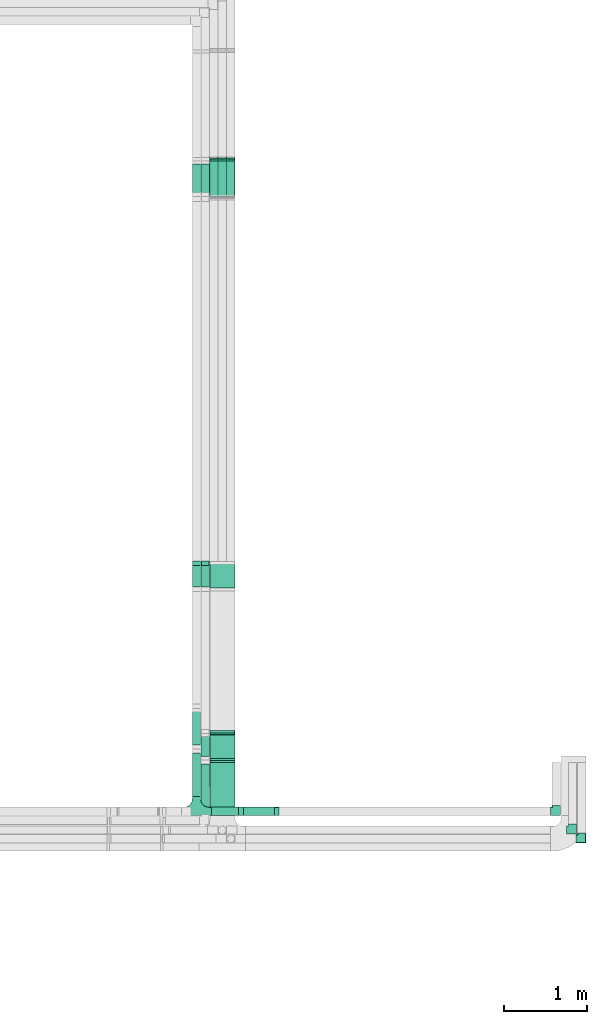
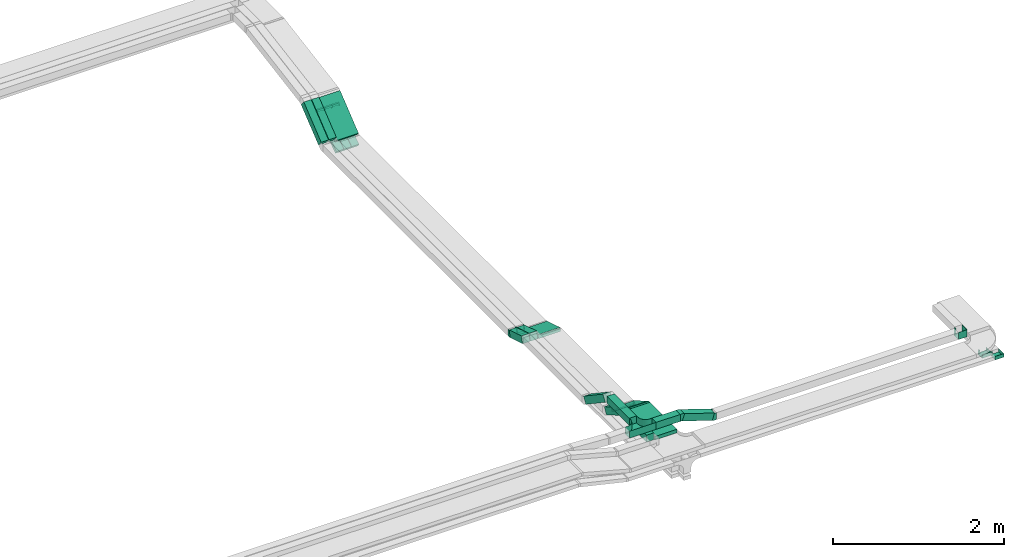
# One storey, part 14 of 18: 17 flow segments, 13 flow fittings.
"""IFC2X3 building model written with IfcOpenShell, lengths in millimetres."""

import ifcopenshell
import ifcopenshell.guid

model = None  # the IFC model being written
_history = None  # IfcOwnerHistory: only IFC2X3 demands one
_inside = {}  # id of a spatial element -> (the spatial element, [elements in it])
_under = {}  # id of a project, library or spatial element -> (it, [spatial elements below it])
_declared = {}  # id of a project -> (the project, [libraries it declares])
_typed = {}  # id of a type object -> (the type object, [elements of that type])
_made_of = {}  # id of a material, layer set ... -> (it, [elements and type objects made of it])


def new_model(schema):
    """Start an empty IFC model of exactly this schema.

    Asked for "IFC4X3", IfcOpenShell would pick the latest addendum, in which some entities
    have other attributes; the version numbers below select the first issue.
    IFC2X3 requires an IfcOwnerHistory on every rooted entity: one is made here for all.
    """
    global model, _history
    if schema == "IFC4X3":
        model = ifcopenshell.file(schema_version=(4, 3, 0, 0))
    else:
        model = ifcopenshell.file(schema=schema)
    _inside.clear()
    _under.clear()
    _declared.clear()
    _typed.clear()
    _made_of.clear()
    _history = None
    if model.schema == "IFC2X3":
        org = make("IfcOrganization", Name="unknown")
        user = make(
            "IfcPersonAndOrganization",
            ThePerson=make("IfcPerson", FamilyName="unknown"),
            TheOrganization=org,
        )
        app = make(
            "IfcApplication",
            ApplicationDeveloper=org,
            Version="unknown",
            ApplicationFullName="unknown",
            ApplicationIdentifier="unknown",
        )
        _history = make(
            "IfcOwnerHistory",
            OwningUser=user,
            OwningApplication=app,
            ChangeAction="ADDED",
            CreationDate=0,
        )
    return model


def make(cls, **values):
    """One entity of the class cls with the attributes given. An attribute that is None is left unset."""
    return model.create_entity(
        cls, **{name: value for name, value in values.items() if value is not None}
    )


def entity(cls, *values):
    """Any entity or typed value of the class cls, its attributes in the order of the schema. None: left unset."""
    e = model.create_entity(cls)
    for i, value in enumerate(values):
        if value is not None:
            e[i] = value
    return e


def rooted(cls, **values):
    """An entity with a GlobalId (a new one), such as an element, a storey or a relation."""
    return make(cls, GlobalId=ifcopenshell.guid.new(), OwnerHistory=_history, **values)


def si_unit(unit_type, name, prefix=None):
    """IfcSIUnit, for example si_unit("LENGTHUNIT", "METRE", prefix="MILLI")."""
    return make("IfcSIUnit", UnitType=unit_type, Prefix=prefix, Name=name)


def converted_unit(unit_type, name, factor, base, dimensions=None, offset=None):
    """IfcConversionBasedUnit, such as the inch: factor (a typed value) times the base unit."""
    return make(
        "IfcConversionBasedUnit"
        if offset is None
        else "IfcConversionBasedUnitWithOffset",
        ConversionOffset=offset,
        Dimensions=None
        if dimensions is None
        else entity("IfcDimensionalExponents", *dimensions),
        UnitType=unit_type,
        Name=name,
        ConversionFactor=make(
            "IfcMeasureWithUnit", ValueComponent=factor, UnitComponent=base
        ),
    )


def derived_unit(unit_type, elements):
    """IfcDerivedUnit: a product of units, each with its exponent."""
    return make(
        "IfcDerivedUnit",
        Elements=[
            make("IfcDerivedUnitElement", Unit=unit, Exponent=power)
            for unit, power in elements
        ],
        UnitType=unit_type,
    )


def assignment(units):
    """IfcUnitAssignment: the units of a project."""
    return None if units is None else make("IfcUnitAssignment", Units=units)


def point(xyz):
    """IfcCartesianPoint."""
    return None if xyz is None else make("IfcCartesianPoint", Coordinates=xyz)


def direction(xyz):
    """IfcDirection."""
    return None if xyz is None else make("IfcDirection", DirectionRatios=xyz)


def frame(location, z_axis=None, x_axis=None):
    """IfcAxis2Placement3D, a coordinate frame: its origin and axes. An axis left out is left unset."""
    return make(
        "IfcAxis2Placement3D",
        Location=point(location),
        Axis=direction(z_axis),
        RefDirection=direction(x_axis),
    )


def frame_2d(location, x_axis=None):
    """IfcAxis2Placement2D, a coordinate frame in the plane: its origin and x axis."""
    return make(
        "IfcAxis2Placement2D", Location=point(location), RefDirection=direction(x_axis)
    )


def origin():
    """The frame at (0, 0, 0) with its axes left unset."""
    return frame((0.0, 0.0, 0.0))


def origin_2d_with_axis():
    """The frame at (0, 0) in the plane with the x axis (1, 0) written out."""
    return frame_2d((0.0, 0.0), x_axis=(1.0, 0.0))


def place(relative_to, where):
    """IfcLocalPlacement: puts the frame where relative to a parent placement (None: the world)."""
    return make(
        "IfcLocalPlacement", PlacementRelTo=relative_to, RelativePlacement=where
    )


def context(
    kind, dimensions, precision=None, world=None, true_north=None, identifier=None
):
    """IfcGeometricRepresentationContext, for example the 3D "Model" context."""
    return make(
        "IfcGeometricRepresentationContext",
        ContextIdentifier=identifier,
        ContextType=kind,
        CoordinateSpaceDimension=dimensions,
        Precision=precision,
        WorldCoordinateSystem=world,
        TrueNorth=true_north,
    )


def subcontext(parent, identifier, kind, view, scale=None):
    """IfcGeometricRepresentationSubContext, for example "Body" below "Model"."""
    return make(
        "IfcGeometricRepresentationSubContext",
        ContextIdentifier=identifier,
        ContextType=kind,
        ParentContext=parent,
        TargetScale=scale,
        TargetView=view,
    )


def project(units=None, contexts=None):
    """IfcProject with its units and contexts."""
    return rooted(
        "IfcProject",
        Name="project",
        RepresentationContexts=contexts,
        UnitsInContext=assignment(units),
    )


def spatial(cls, under=None, at=None, **own):
    """A site, building, storey or space (cls), placed at a placement, below another one or the project."""
    s = rooted(cls, ObjectPlacement=at, **own)
    if under is not None:
        _under.setdefault(under.id(), (under, []))[1].append(s)
    return s


def profile(cls, at=None, kind="AREA", **sizes):
    """A parametric profile (cls). Its sizes go by their IFC names, for example OverallWidth=200.0."""
    return make(cls, ProfileType=kind, Position=at, **sizes)


def rectangle(**sizes):
    """IfcRectangleProfileDef."""
    return profile("IfcRectangleProfileDef", **sizes)


def extrude(swept, where, along, depth):
    """IfcExtrudedAreaSolid: the profile swept, set in the frame where, extruded along a direction by depth."""
    return make(
        "IfcExtrudedAreaSolid",
        SweptArea=swept,
        Position=where,
        ExtrudedDirection=direction(along),
        Depth=depth,
    )


def faces_of(points, faces, orient=None, outer=None):
    """IfcFace entities. A face is a list of loops; a loop is a list of indices into points, from 0.

    orient and outer hold one flag for each loop. By default every Orientation is true, the
    first loop of a face is its IfcFaceOuterBound and the others are IfcFaceBound.
    """
    made = []
    for i, loops in enumerate(faces):
        bounds = []
        for j, loop in enumerate(loops):
            is_outer = j == 0 if outer is None else outer[i][j]
            bounds.append(
                make(
                    "IfcFaceOuterBound" if is_outer else "IfcFaceBound",
                    Bound=make("IfcPolyLoop", Polygon=[points[k] for k in loop]),
                    Orientation=True if orient is None else orient[i][j],
                )
            )
        made.append(make("IfcFace", Bounds=bounds))
    return made


def faceted_brep(points, faces, orient=None, outer=None, voids=None):
    """IfcFacetedBrep: a solid bounded by flat faces; with voids (closed shells), ...WithVoids."""
    shared = [point(p) for p in points]
    hull = make("IfcClosedShell", CfsFaces=faces_of(shared, faces, orient, outer))
    if voids is None:
        return make("IfcFacetedBrep", Outer=hull)
    return make(
        "IfcFacetedBrepWithVoids",
        Outer=hull,
        Voids=[
            make(cls, CfsFaces=faces_of(shared, fs, o, b)) for cls, fs, o, b in voids
        ],
    )


def shape(context_of_items, identifier, shape_type, items):
    """IfcShapeRepresentation: the items that make up one representation, for example the "Body"."""
    return make(
        "IfcShapeRepresentation",
        ContextOfItems=context_of_items,
        RepresentationIdentifier=identifier,
        RepresentationType=shape_type,
        Items=items,
    )


def source(mapping_origin, context_of_items, identifier, shape_type, items):
    """IfcRepresentationMap: a shape defined once, which mapped items show again and again."""
    return make(
        "IfcRepresentationMap",
        MappingOrigin=mapping_origin,
        MappedRepresentation=shape(context_of_items, identifier, shape_type, items),
    )


def transform(
    local_origin,
    x_axis=None,
    y_axis=None,
    z_axis=None,
    scale=None,
    scale2=None,
    scale3=None,
    uniform=True,
):
    """IfcCartesianTransformationOperator3D, or its non-uniform kind. x_axis, y_axis, z_axis: its Axis1, 2, 3."""
    if uniform:
        return make(
            "IfcCartesianTransformationOperator3D",
            Axis1=direction(x_axis),
            Axis2=direction(y_axis),
            LocalOrigin=point(local_origin),
            Scale=scale,
            Axis3=direction(z_axis),
        )
    return make(
        "IfcCartesianTransformationOperator3DnonUniform",
        Axis1=direction(x_axis),
        Axis2=direction(y_axis),
        LocalOrigin=point(local_origin),
        Scale=scale,
        Axis3=direction(z_axis),
        Scale2=scale2,
        Scale3=scale3,
    )


def mapped(mapping_source, mapping_target):
    """IfcMappedItem: shows the shape of a source again, moved by a transform."""
    return make(
        "IfcMappedItem", MappingSource=mapping_source, MappingTarget=mapping_target
    )


def material(Name=None, Category=None):
    """IfcMaterial."""
    return make("IfcMaterial", Name=Name, Category=Category)


def made_of(thing, what):
    """Note that an element or type object is made of a material, layer set ...; save() writes the relation."""
    if what is not None:
        _made_of.setdefault(what.id(), (what, []))[1].append(thing)
    return thing


def type_object(cls, material=None, **own):
    """A type object (cls), such as IfcWallType, which elements share."""
    return made_of(rooted(cls, **own), material)


def type_shapes(of_type, sources):
    """Give a type object the sources (RepresentationMaps) that its elements show as mapped items."""
    of_type.RepresentationMaps = sources


def element(
    cls,
    number,
    at=None,
    inside=None,
    cuts=None,
    type_object=None,
    material=None,
    context=None,
    identifier="Body",
    shape_type=None,
    held_by="IfcProductDefinitionShape",
    body=None,
    shapes=None,
    **own,
):
    """One element of the class cls, such as IfcWall. Its Tag is "e" and its number.

    at: its placement. inside: the storey or other place that contains it. cuts: it is an
    opening in that element (IfcRelVoidsElement). A single representation is given by context,
    identifier, shape_type and body (its items); several are given by shapes. held_by: the class
    of the entity that holds the representations. save() writes the other relations.
    """
    e = rooted(cls, Tag="e%d" % number, ObjectPlacement=at, **own)
    if body is not None:
        shapes = [shape(context, identifier, shape_type, body)]
    if shapes is not None:
        e.Representation = make(held_by, Representations=shapes)
    if inside is not None:
        _inside.setdefault(inside.id(), (inside, []))[1].append(e)
    if cuts is not None:
        rooted(
            "IfcRelVoidsElement", RelatingBuildingElement=cuts, RelatedOpeningElement=e
        )
    if type_object is not None:
        _typed.setdefault(type_object.id(), (type_object, []))[1].append(e)
    return made_of(e, material)


def aggregate(whole, parts):
    """IfcRelAggregates: a whole, such as a stair, and the parts it consists of."""
    return rooted("IfcRelAggregates", RelatingObject=whole, RelatedObjects=parts)


def save(model, path):
    """Write the relations noted so far, then the file.

    IfcRelAggregates (storeys below a building ...), IfcRelContainedInSpatialStructure (elements
    in a storey), IfcRelDefinesByType, IfcRelAssociatesMaterial and IfcRelDeclares: one each for
    every whole, place, type object, material and project.
    """
    for whole, parts in _under.values():
        aggregate(whole, parts)
    for where, things in _inside.values():
        rooted(
            "IfcRelContainedInSpatialStructure",
            RelatedElements=things,
            RelatingStructure=where,
        )
    for kind, things in _typed.values():
        rooted("IfcRelDefinesByType", RelatedObjects=things, RelatingType=kind)
    for what, things in _made_of.values():
        rooted("IfcRelAssociatesMaterial", RelatedObjects=things, RelatingMaterial=what)
    for by, libraries in _declared.values():
        rooted("IfcRelDeclares", RelatingContext=by, RelatedDefinitions=libraries)
    model.write(path)


model = new_model("IFC2X3")

# Units and contexts
model_context = context("Model", 3, precision=0.01, world=origin(), true_north=direction((6.12303176911189e-17, 1.0)))
body_context = subcontext(model_context, "Body", "Model", "MODEL_VIEW")
ifc_project = project(units=[si_unit("LENGTHUNIT", "METRE", prefix="MILLI"), si_unit("AREAUNIT", "SQUARE_METRE"), si_unit("VOLUMEUNIT", "CUBIC_METRE"), converted_unit("PLANEANGLEUNIT", "DEGREE", entity("IfcRatioMeasure", 0.0174532925199433), si_unit("PLANEANGLEUNIT", "RADIAN"), dimensions=[0, 0, 0, 0, 0, 0, 0]), si_unit("MASSUNIT", "GRAM", prefix="KILO"), derived_unit("MASSDENSITYUNIT", [(si_unit("MASSUNIT", "GRAM", prefix="KILO"), 1), (si_unit("LENGTHUNIT", "METRE"), -3)]), derived_unit("MOMENTOFINERTIAUNIT", [(si_unit("LENGTHUNIT", "METRE"), 4)]), si_unit("TIMEUNIT", "SECOND"), si_unit("FREQUENCYUNIT", "HERTZ"), si_unit("THERMODYNAMICTEMPERATUREUNIT", "DEGREE_CELSIUS"), derived_unit("THERMALTRANSMITTANCEUNIT", [(si_unit("MASSUNIT", "GRAM", prefix="KILO"), 1), (si_unit("THERMODYNAMICTEMPERATUREUNIT", "KELVIN"), -1), (si_unit("TIMEUNIT", "SECOND"), -3)]), derived_unit("VOLUMETRICFLOWRATEUNIT", [(si_unit("LENGTHUNIT", "METRE"), 3), (si_unit("TIMEUNIT", "SECOND"), -1)]), derived_unit("MASSFLOWRATEUNIT", [(si_unit("MASSUNIT", "GRAM", prefix="KILO"), 1), (si_unit("TIMEUNIT", "SECOND"), -1)]), derived_unit("ROTATIONALFREQUENCYUNIT", [(si_unit("TIMEUNIT", "SECOND"), -1)]), si_unit("ELECTRICCURRENTUNIT", "AMPERE"), si_unit("ELECTRICVOLTAGEUNIT", "VOLT"), si_unit("POWERUNIT", "WATT"), si_unit("FORCEUNIT", "NEWTON", prefix="KILO"), si_unit("ILLUMINANCEUNIT", "LUX"), si_unit("LUMINOUSFLUXUNIT", "LUMEN"), si_unit("LUMINOUSINTENSITYUNIT", "CANDELA"), derived_unit("USERDEFINED", [(si_unit("MASSUNIT", "GRAM", prefix="KILO"), -1), (si_unit("LENGTHUNIT", "METRE"), -2), (si_unit("TIMEUNIT", "SECOND"), 3), (si_unit("LUMINOUSFLUXUNIT", "LUMEN"), 1)]), derived_unit("LINEARVELOCITYUNIT", [(si_unit("LENGTHUNIT", "METRE"), 1), (si_unit("TIMEUNIT", "SECOND"), -1)]), si_unit("PRESSUREUNIT", "PASCAL"), derived_unit("USERDEFINED", [(si_unit("LENGTHUNIT", "METRE"), -2), (si_unit("MASSUNIT", "GRAM", prefix="KILO"), 1), (si_unit("TIMEUNIT", "SECOND"), -2)]), derived_unit("LINEARFORCEUNIT", [(si_unit("MASSUNIT", "GRAM", prefix="KILO"), 1), (si_unit("LENGTHUNIT", "METRE"), 1), (si_unit("TIMEUNIT", "SECOND"), -2), (si_unit("LENGTHUNIT", "METRE"), -1)]), derived_unit("PLANARFORCEUNIT", [(si_unit("MASSUNIT", "GRAM", prefix="KILO"), 1), (si_unit("LENGTHUNIT", "METRE"), 1), (si_unit("TIMEUNIT", "SECOND"), -2), (si_unit("LENGTHUNIT", "METRE"), -2)])], contexts=[model_context])

# Site, building, storey
site_placement = place(None, frame((0.0, -0.00077364408347762, 0.0)))
site = spatial("IfcSite", under=ifc_project, at=site_placement, CompositionType="ELEMENT")
building_placement = place(site_placement, origin())
building = spatial("IfcBuilding", under=site, at=building_placement, CompositionType="ELEMENT")
storey_placement = place(building_placement, frame((0.0, 0.0, 19800.0)))
storey = spatial("IfcBuildingStorey", under=building, at=storey_placement, CompositionType="ELEMENT", Elevation=19800.0)

# Flow segments
cable_carrier_segment_type = type_object("IfcCableCarrierSegmentType", PredefinedType="CABLETRAYSEGMENT")
flow_segment_1_placement = place(storey_placement, frame((64391.9138834223, 17411.1480452111, 2720.97492503869)))
element("IfcFlowSegment", 1, at=flow_segment_1_placement, inside=storey, type_object=cable_carrier_segment_type, context=body_context, shape_type="SweptSolid", body=[
    extrude(rectangle(XDim=49.9999999999999, YDim=558.364474472639, at=frame_2d((5.11590769747272e-13, 2.36788366692053e-12), x_axis=(0.0, 1.0))), frame((0.0, 232.698357954974, 195.123723748153), z_axis=(1.0, 0.0, 0.0), x_axis=(0.0, -0.777145961456977, -0.62932039104983)), (0.0, 0.0, 1.0), 300.000000000001),
])
flow_segment_2_placement = place(storey_placement, frame((64285.5285540871, 17401.0506289851, 2737.8789554889)))
element("IfcFlowSegment", 2, at=flow_segment_2_placement, inside=storey, type_object=cable_carrier_segment_type, context=body_context, shape_type="SweptSolid", body=[
    extrude(rectangle(XDim=100.000000000002, YDim=99.9999999999916, at=origin_2d_with_axis()), frame((50.0167972546053, 31.4672641902552, 38.8583059544737), z_axis=(-3.20308930122839e-05, 0.777145960996682, 0.6293203908031), x_axis=(0.0, -0.629320391125934, 0.777145961395349)), (0.0, 0.0, 1.0), 524.408740760887),
])
flow_segment_3_placement = place(storey_placement, frame((64180.0593442443, 17401.0504555113, 2737.87881503436)))
element("IfcFlowSegment", 3, at=flow_segment_3_placement, inside=storey, type_object=cable_carrier_segment_type, context=body_context, shape_type="SweptSolid", body=[
    extrude(rectangle(XDim=100.000000000001, YDim=99.9999999999946, at=frame_2d((6.78568312650896e-13, 0.0), x_axis=(1.0, 0.0))), frame((50.0, 31.4660195524966, 38.8572980728524), z_axis=(0.0, 0.777145961456953, 0.62932039104986), x_axis=(0.0, -0.62932039104986, 0.777145961456953)), (0.0, 0.0, 1.0), 524.410565226229),
])
flow_segment_4_placement = place(storey_placement, frame((64593.0376989449, 17401.2001656463, 2566.87354238661)))
element("IfcFlowSegment", 4, at=flow_segment_4_placement, inside=storey, type_object=cable_carrier_segment_type, context=body_context, shape_type="SweptSolid", body=[
    extrude(rectangle(XDim=50.0000000000052, YDim=534.379820039847, at=frame_2d((0.0, 0.0), x_axis=(0.0, 1.0))), frame((0.0, 234.433439273437, 171.822768986589), z_axis=(1.0, 0.0, 0.0), x_axis=(0.0, 0.824451507844614, 0.565932603065721)), (0.0, 0.0, 1.0), 99.9999999999946),
])
for number, where in (
    (5, (64490.5275144406, 17401.2001656506, 2566.87354238954)),
    (6, (64388.5726926723, 17401.2001656506, 2566.87354238954)),
):
    element("IfcFlowSegment", number, at=place(storey_placement, frame(where)), inside=storey, type_object=cable_carrier_segment_type, context=body_context, shape_type="SweptSolid", body=[
        extrude(rectangle(XDim=50.0000000000052, YDim=534.379820034669, at=frame_2d((0.0, 0.0), x_axis=(0.0, 1.0))), frame((0.0, 234.433439271302, 171.822768985125), z_axis=(1.0, 0.0, 0.0), x_axis=(0.0, 0.824451507844611, 0.565932603065725)), (0.0, 0.0, 1.0), 99.9999999999946),
    ])
flow_segment_5_placement = place(storey_placement, frame((64393.0376989449, 9945.00008284603, 3000.0)))
element("IfcFlowSegment", 7, at=flow_segment_5_placement, inside=storey, type_object=cable_carrier_segment_type, context=body_context, shape_type="SweptSolid", body=[
    extrude(rectangle(XDim=637.211482764682, YDim=300.000000000001, at=frame_2d((1.10844666778576e-12, -4.33431068813661e-12), x_axis=(1.0, 0.0))), frame((150.0, 318.60574138234, 0.0), z_axis=(0.0, 0.0, 1.0), x_axis=(0.0, 1.0, 0.0)), (0.0, 0.0, 1.0), 49.9999999999973),
])
flow_segment_6_placement = place(storey_placement, frame((64393.0376989449, 10606.5416926296, 2813.21796769732)))
element("IfcFlowSegment", 8, at=flow_segment_6_placement, inside=storey, type_object=cable_carrier_segment_type, context=body_context, shape_type="SweptSolid", body=[
    extrude(rectangle(XDim=49.9999999999989, YDim=360.525588832415, at=frame_2d((-2.95585778076202e-12, 7.95807864051312e-13), x_axis=(0.0, 1.0))), frame((0.0, 168.612159321606, 111.782032302714), z_axis=(1.0, 0.0, 0.0), x_axis=(0.0, 0.866025403784418, -0.500000000000036)), (0.0, 0.0, 1.0), 300.000000000001),
])
flow_segment_7_placement = place(storey_placement, frame((64285.5467024828, 10605.6442330113, 2823.26916208132)))
element("IfcFlowSegment", 9, at=flow_segment_7_placement, inside=storey, type_object=cable_carrier_segment_type, context=body_context, shape_type="SweptSolid", body=[
    extrude(rectangle(XDim=99.9999999999989, YDim=99.9999999999946, at=origin_2d_with_axis()), frame((50.0, 25.0, 210.16350531605), z_axis=(0.0, 0.866025403784326, -0.500000000000195), x_axis=(0.0, 0.500000000000195, 0.866025403784326)), (0.0, 0.0, 1.0), 333.724470253517),
])
flow_segment_8_placement = place(storey_placement, frame((64285.5467024828, 9956.0000815939, 3000.0)))
element("IfcFlowSegment", 10, at=flow_segment_8_placement, inside=storey, type_object=cable_carrier_segment_type, context=body_context, shape_type="SweptSolid", body=[
    extrude(rectangle(XDim=612.814024398429, YDim=99.9999999999946, at=frame_2d((0.0, 4.33075797445781e-12), x_axis=(1.0, 0.0))), frame((50.0, 306.407012199218, 0.0), z_axis=(0.0, 0.0, 1.0), x_axis=(0.0, 1.0, 0.0)), (0.0, 0.0, 1.0), 100.000000000003),
])
flow_segment_9_placement = place(storey_placement, frame((64180.0597687348, 10175.000082846, 3146.68251695043)))
element("IfcFlowSegment", 11, at=flow_segment_9_placement, inside=storey, type_object=cable_carrier_segment_type, context=body_context, shape_type="SweptSolid", body=[
    extrude(rectangle(XDim=523.063851606019, YDim=99.9999999999946, at=origin_2d_with_axis()), frame((50.0, 261.53192580301, 0.0), z_axis=(0.0, 0.0, 1.0), x_axis=(0.0, 1.0, 0.0)), (0.0, 0.0, 1.0), 100.000000000003),
])
flow_segment_10_placement = place(storey_placement, frame((64765.1718243244, 9945.00008284604, 3009.28144340263)))
element("IfcFlowSegment", 12, at=flow_segment_10_placement, inside=storey, type_object=cable_carrier_segment_type, context=body_context, shape_type="SweptSolid", body=[
    extrude(rectangle(XDim=99.9999999999972, YDim=99.9999999999989, at=origin_2d_with_axis()), frame((15.5858337745195, 50.0, 180.610875314588), z_axis=(0.950175096611784, 0.0, -0.311716675490399), x_axis=(0.311716675490399, 0.0, 0.950175096611784)), (0.0, 0.0, 1.0), 426.997112921798),
])
flow_segment_11_placement = place(storey_placement, frame((64410.0597687348, 9945.00008284604, 3146.68251695043)))
element("IfcFlowSegment", 13, at=flow_segment_11_placement, inside=storey, type_object=cable_carrier_segment_type, context=body_context, shape_type="SweptSolid", body=[
    extrude(rectangle(XDim=328.216762954596, YDim=99.9999999999989, at=origin_2d_with_axis()), frame((164.108381477298, 50.0, 0.0)), (0.0, 0.0, 1.0), 100.000000000003),
])
flow_segment_12_placement = place(storey_placement, frame((64180.0597687348, 10737.8410861841, 2829.0378787811)))
element("IfcFlowSegment", 14, at=flow_segment_12_placement, inside=storey, type_object=cable_carrier_segment_type, context=body_context, shape_type="SweptSolid", body=[
    extrude(rectangle(XDim=99.9999999999974, YDim=99.9999999999946, at=frame_2d((0.0, 8.66506866259442e-12), x_axis=(1.0, 0.0))), frame((50.0, 27.8399213668352, 347.078648831679), z_axis=(0.0, 0.830647645705059, -0.556798427336718), x_axis=(0.0, 0.556798427336718, 0.830647645705059)), (0.0, 0.0, 1.0), 548.755620607478),
])
flow_segment_13_placement = place(storey_placement, frame((64393.0376989449, 12673.6918025553, 2704.95747891862)))
element("IfcFlowSegment", 15, at=flow_segment_13_placement, inside=storey, type_object=cable_carrier_segment_type, context=body_context, shape_type="SweptSolid", body=[
    extrude(rectangle(XDim=50.0000000000024, YDim=315.590748852371, at=frame_2d((0.0, 0.0), x_axis=(0.0, 1.0))), frame((0.0, 158.209759650795, 70.0425215174395), z_axis=(1.0, 0.0, 0.0), x_axis=(0.0, 0.956304755963003, -0.292371704722843)), (0.0, 0.0, 1.0), 300.000000000001),
])
flow_segment_14_placement = place(storey_placement, frame((64285.5467024828, 12676.6495457763, 2708.42445845428)))
element("IfcFlowSegment", 16, at=flow_segment_14_placement, inside=storey, type_object=cable_carrier_segment_type, context=body_context, shape_type="SweptSolid", body=[
    extrude(rectangle(XDim=100.000000000005, YDim=99.9999999999946, at=frame_2d((0.0, 3.19744231092045e-13), x_axis=(0.0, 1.0))), frame((50.0, 14.6185852361423, 135.713790648688), z_axis=(0.0, 0.956304755963, -0.292371704722853), x_axis=(-1.0, 0.0, 0.0)), (0.0, 0.0, 1.0), 300.639738492675),
])
flow_segment_15_placement = place(storey_placement, frame((64180.0597687348, 12676.6507563411, 2708.42445845429)))
element("IfcFlowSegment", 17, at=flow_segment_15_placement, inside=storey, type_object=cable_carrier_segment_type, context=body_context, shape_type="SweptSolid", body=[
    extrude(rectangle(XDim=100.000000000005, YDim=99.9999999999946, at=frame_2d((-8.66506866259442e-12, 0.0), x_axis=(0.0, 1.0))), frame((50.0, 14.6185852361423, 135.713420541873), z_axis=(0.0, 0.956304755963006, -0.292371704722833), x_axis=(-1.0, 0.0, 0.0)), (0.0, 0.0, 1.0), 300.63847261503),
])

# Flow fittings
ifc_material = material()
cable_carrier_fitting_type_1 = type_object("IfcCableCarrierFittingType", PredefinedType="NOTDEFINED", material=ifc_material)
shared_shape_1 = source(origin(), body_context, "Body", "Brep", [
    faceted_brep([(-17.0803377956261, -25.0, 50.0), (-17.080337795626, 25.0, 50.0), (-17.080337795626, 25.0, 47.4600000101635), (-17.0803377956261, -22.4600000101599, 47.4600000101635), (-17.0803377956261, -22.4600000101599, -47.4600000101565), (-17.080337795626, 25.0, -47.4600000101565), (-17.080337795626, 25.0, -50.0), (-17.0803377956261, -25.0, -50.0), (25.9848753027497, -15.5410487005638, 50.0), (25.9848753027497, -15.5410487005638, -50.0), (5.03147604697358, 29.8566941907743, -50.0), (5.03147604697358, 29.8566941907743, -47.4600000101565), (24.920442624814, -13.2348433709087, -47.4600000101565), (24.920442624814, -13.2348433709087, 47.4600000101635), (5.03147604697358, 29.8566941907743, 47.4600000101635), (5.03147604697358, 29.8566941907743, 50.0), (5.49106263437606, -25.0, 50.0), (-5.49106263437527, 25.0, 50.0), (-5.49106263437527, 25.0, 47.4600000101635), (4.93317067295496, -22.46000001016, 47.4600000101635), (4.93317067295496, -22.46000001016, -47.4600000101565), (-5.49106263437527, 25.0, -47.4600000101565), (-5.49106263437526, 25.0, -50.0), (5.49106263437596, -25.0, -50.0)], [[[0, 1, 2, 3, 4, 5, 6, 7]], [[8, 9, 10, 11, 12, 13, 14, 15]], [[1, 0, 16, 8, 15, 17]], [[2, 1, 17, 18]], [[3, 2, 18, 14, 13, 19]], [[4, 3, 19, 20]], [[5, 4, 20, 12, 11, 21]], [[6, 5, 21, 22]], [[7, 6, 22, 10, 9, 23]], [[0, 7, 23, 16]], [[18, 17, 15, 14]], [[20, 19, 13, 12]], [[22, 21, 11, 10]], [[16, 23, 9, 8]]]),
])
type_shapes(cable_carrier_fitting_type_1, [shared_shape_1])
for number, where, z_axis, x_axis in (
    (18, (64643.0376989449, 17870.0006393666, 2899.57411269359), (1.0, 0.0, 0.0), (0.0, -0.985728987268033, -0.168340023938269)),
    (19, (64540.5275144406, 17870.0006393666, 2899.5741126936), (1.0, 0.0, 0.0), (0.0, -0.985728987268033, -0.168340023938269)),
    (20, (64438.5726926723, 17870.0006393666, 2899.5741126936), (1.0, 0.0, 0.0), (0.0, -0.985728987268033, -0.168340023938269)),
):
    element("IfcFlowFitting", number, at=place(storey_placement, frame(where, z_axis=z_axis, x_axis=x_axis)), inside=storey, type_object=cable_carrier_fitting_type_1, material=ifc_material, context=body_context, shape_type="MappedRepresentation", body=[
        mapped(shared_shape_1, transform((0.0, 0.0, 0.0), scale=1.0)),
    ])
cable_carrier_fitting_type_2 = type_object("IfcCableCarrierFittingType", PredefinedType="NOTDEFINED", material=ifc_material)
shared_shape_2 = source(origin(), body_context, "Body", "Brep", [
    faceted_brep([(-70.0, 50.0, -25.0), (-70.0, -50.0, -25.0), (-70.0, -50.0, 25.0), (-70.0, -47.4600000101598, 25.0), (-70.0, -47.4600000101598, -22.4600000101565), (-70.0, 47.4600000101602, -22.4600000101565), (-70.0, 47.4600000101602, 25.0), (-70.0, 50.0, 25.0), (-50.0, 50.0, -25.0), (-50.0, 70.0, -25.0), (50.0, 70.0, -25.0), (50.0, -50.0, -25.0), (50.0, -50.0, 25.0), (50.0, 70.0, 25.0), (47.4600000101603, 70.0, 25.0), (47.4600000101596, -47.4600000101602, 25.0), (47.4600000101596, -47.4600000101602, -22.4600000101565), (47.4600000101603, 70.0, -22.4600000101565), (-47.4600000101597, 70.0, -22.4600000101565), (-47.4600000101602, 47.4600000101602, -22.4600000101565), (-47.4600000101602, 47.4600000101602, 25.0), (-47.4600000101597, 70.0, 25.0), (-50.0, 70.0, 25.0), (-50.0, 50.0, 25.0)], [[[0, 1, 2, 3, 4, 5, 6, 7]], [[1, 0, 8, 9, 10, 11]], [[2, 1, 11, 12]], [[3, 2, 12, 13, 14, 15]], [[4, 3, 15, 16]], [[5, 4, 16, 17, 18, 19]], [[6, 5, 19, 20]], [[7, 6, 20, 21, 22, 23]], [[0, 7, 23, 8]], [[9, 22, 21, 18, 17, 14, 13, 10]], [[12, 11, 10, 13]], [[16, 15, 14, 17]], [[20, 19, 18, 21]], [[8, 23, 22, 9]]]),
])
type_shapes(cable_carrier_fitting_type_2, [shared_shape_2])
for number, where in (
    (21, (68767.4381955181, 9770.00008284602, 2825.0)),
    (22, (68880.581617303, 9665.00008284603, 2825.0)),
):
    element("IfcFlowFitting", number, at=place(storey_placement, frame(where)), inside=storey, type_object=cable_carrier_fitting_type_2, material=ifc_material, context=body_context, shape_type="MappedRepresentation", body=[
        mapped(shared_shape_2, transform((0.0, 0.0, 0.0), scale=1.0)),
    ])
cable_carrier_fitting_type_3 = type_object("IfcCableCarrierFittingType", PredefinedType="NOTDEFINED", material=ifc_material)
shared_shape_3 = source(origin(), body_context, "Body", "Brep", [
    faceted_brep([(-19.7372055837126, -25.0, 150.0), (-19.7372055837125, 25.0, 150.0), (-19.7372055837125, 25.0, 147.460000010164), (-19.7372055837126, -22.4600000101599, 147.460000010164), (-19.7372055837126, -22.4600000101599, -147.460000010156), (-19.7372055837125, 25.0, -147.460000010156), (-19.7372055837125, 25.0, -150.0), (-19.7372055837126, -25.0, -150.0), (29.5929214352125, -11.7820323027537, 150.0), (29.5929214352125, -11.7820323027538, -150.0), (4.59292143521078, 31.5192378864672, -150.0), (4.59292143521077, 31.5192378864672, -147.460000010156), (28.3229214402924, -9.58232778594015, -147.460000010156), (28.3229214402924, -9.58232778594014, 147.460000010164), (4.59292143521078, 31.5192378864672, 147.460000010164), (4.59292143521077, 31.5192378864672, 150.0), (6.69872981077903, -25.0, 150.0), (-6.69872981077822, 25.0, 150.0), (-6.69872981077822, 25.0, 147.460000010164), (6.01813886472617, -22.46000001016, 147.460000010164), (6.01813886472617, -22.46000001016, -147.460000010156), (-6.69872981077822, 25.0, -147.460000010156), (-6.69872981077822, 25.0, -150.0), (6.69872981077891, -25.0, -150.0)], [[[0, 1, 2, 3, 4, 5, 6, 7]], [[8, 9, 10, 11, 12, 13, 14, 15]], [[1, 0, 16, 8, 15, 17]], [[2, 1, 17, 18]], [[3, 2, 18, 14, 13, 19]], [[4, 3, 19, 20]], [[5, 4, 20, 12, 11, 21]], [[6, 5, 21, 22]], [[7, 6, 22, 10, 9, 23]], [[0, 7, 23, 16]], [[18, 17, 15, 14]], [[20, 19, 13, 12]], [[22, 21, 11, 10]], [[16, 23, 9, 8]]]),
])
type_shapes(cable_carrier_fitting_type_3, [shared_shape_3])
for number, where, z_axis, x_axis in (
    (23, (64543.0376989449, 10601.9487711944, 3025.0), (-1.0, 0.0, 0.0), (0.0, 1.0, 0.0)),
    (24, (64543.0376989449, 10948.3589327081, 2825.0), (1.0, 0.0, 0.0), (0.0, 0.866025403784418, -0.500000000000036)),
):
    element("IfcFlowFitting", number, at=place(storey_placement, frame(where, z_axis=z_axis, x_axis=x_axis)), inside=storey, type_object=cable_carrier_fitting_type_3, material=ifc_material, context=body_context, shape_type="MappedRepresentation", body=[
        mapped(shared_shape_3, transform((0.0, 0.0, 0.0), scale=1.0)),
    ])
cable_carrier_fitting_type_4 = type_object("IfcCableCarrierFittingType", PredefinedType="NOTDEFINED", material=ifc_material)
shared_shape_4 = source(origin(), body_context, "Body", "Brep", [
    faceted_brep([(-70.0, 50.0, -50.0), (-70.0, -50.0, -50.0), (-70.0, -50.0, 50.0), (-70.0, -47.4600000101598, 50.0), (-70.0, -47.4600000101598, -47.4600000101565), (-70.0, 47.4600000101602, -47.4600000101565), (-70.0, 47.4600000101602, 50.0), (-70.0, 50.0, 50.0), (-50.0, 50.0, -50.0), (-50.0, 70.0, -50.0), (50.0, 70.0, -50.0), (50.0, -50.0, -50.0), (50.0, -50.0, 50.0), (50.0, 70.0, 50.0), (47.4600000101603, 70.0, 50.0), (47.4600000101596, -47.4600000101602, 50.0), (47.4600000101596, -47.4600000101602, -47.4600000101565), (47.4600000101603, 70.0, -47.4600000101565), (-47.4600000101597, 70.0, -47.4600000101565), (-47.4600000101602, 47.4600000101602, -47.4600000101565), (-47.4600000101602, 47.4600000101602, 50.0), (-47.4600000101597, 70.0, 50.0), (-50.0, 70.0, 50.0), (-50.0, 50.0, 50.0)], [[[0, 1, 2, 3, 4, 5, 6, 7]], [[1, 0, 8, 9, 10, 11]], [[2, 1, 11, 12]], [[3, 2, 12, 13, 14, 15]], [[4, 3, 15, 16]], [[5, 4, 16, 17, 18, 19]], [[6, 5, 19, 20]], [[7, 6, 20, 21, 22, 23]], [[0, 7, 23, 8]], [[9, 22, 21, 18, 17, 14, 13, 10]], [[12, 11, 10, 13]], [[16, 15, 14, 17]], [[20, 19, 18, 21]], [[8, 23, 22, 9]]]),
])
type_shapes(cable_carrier_fitting_type_4, [shared_shape_4])
flow_fitting_1_placement = place(storey_placement, frame((68573.2642765869, 9995.00008284606, 3050.0)))
element("IfcFlowFitting", 25, at=flow_fitting_1_placement, inside=storey, type_object=cable_carrier_fitting_type_4, material=ifc_material, context=body_context, shape_type="MappedRepresentation", body=[
    mapped(shared_shape_4, transform((0.0, 0.0, 0.0), scale=1.0)),
])
cable_carrier_fitting_type_5 = type_object("IfcCableCarrierFittingType", PredefinedType="NOTDEFINED", material=ifc_material)
shared_shape_5 = source(origin(), body_context, "Body", "Brep", [
    faceted_brep([(-53.4074173710859, -124.118095489752, 50.0), (-50.0, -150.0, 50.0), (-50.0, -180.0, 50.0), (-49.1999999999934, -180.0, 50.0), (-49.1999999999926, -150.0, 50.0), (-52.6346767100545, -123.91104025367, 50.0), (-62.7046392985216, -99.6000000000037, 50.0), (-78.7236364563899, -78.7236364563991, 50.0), (-99.5999999999949, -62.7046392985315, 50.0), (-123.911040253662, -52.6346767100651, 50.0), (-150.0, -49.2000000000047, 50.0), (-180.0, -49.2000000000047, 50.0), (-180.0, -50.0, 50.0), (-150.0, -50.0, 50.0), (-124.118095489745, -53.4074173710983, 50.0), (-100.0, -63.3974596215602, 50.0), (-79.2893218813398, -79.2893218813488, 50.0), (-63.3974596215496, -100.0, 50.0), (180.0, -50.0, 50.0), (180.0, -49.2000000000047, 50.0), (150.0, -49.2000000000046, 50.0), (123.911040253717, -52.634676710066, 50.0), (99.6000000000452, -62.7046392985316, 50.0), (78.7236364564342, -78.7236364563979, 50.0), (62.7046392985581, -99.6000000000012, 50.0), (52.6346767100809, -123.911040253668, 50.0), (49.200000000007, -150.0, 50.0), (49.2000000000071, -180.0, 50.0), (50.0, -180.0, 50.0), (50.0, -150.0, 50.0), (53.4074173711136, -124.11809548975, 50.0), (63.3974596215874, -100.0, 50.0), (79.2893218813853, -79.2893218813486, 50.0), (100.0, -63.3974596215613, 50.0), (124.1180954898, -53.4074173710999, 50.0), (150.0, -50.0, 50.0), (180.0, 49.1999999999958, 50.0), (180.0, 50.0, 50.0), (-180.0, 50.0, 50.0), (-180.0, 49.1999999999958, 50.0), (-180.0, -50.0, -50.0), (-180.0, 50.0, -50.0), (180.0, 50.0, -50.0), (180.0, -50.0, -50.0), (150.0, -50.0, -50.0), (124.1180954898, -53.4074173710999, -50.0), (100.0, -63.3974596215613, -50.0), (79.2893218813853, -79.2893218813486, -50.0), (63.3974596215874, -100.0, -50.0), (53.4074173711136, -124.11809548975, -50.0), (50.0, -150.0, -50.0), (50.0, -180.0, -50.0), (-50.0, -180.0, -50.0), (-50.0, -150.0, -50.0), (-53.4074173710859, -124.118095489752, -50.0), (-63.3974596215496, -100.0, -50.0), (-79.2893218813398, -79.2893218813488, -50.0), (-100.0, -63.3974596215602, -50.0), (-124.118095489745, -53.4074173710983, -50.0), (-150.0, -50.0, -50.0), (-50.0, -150.0, -49.1999999999851), (49.2000000000071, -180.0, -49.1999999999851), (-49.1999999999934, -180.0, -49.1999999999851), (-49.1999999999926, -150.0, -49.1999999999851), (-150.0, -49.2000000000047, -49.1999999999851), (-180.0, -49.2000000000047, -49.1999999999851), (180.0, -49.2000000000047, -49.1999999999851), (150.0, -49.2000000000047, -49.1999999999851), (-180.0, 49.1999999999958, -49.1999999999851), (-150.0, -50.0, -49.1999999999851), (150.0, -50.0, -49.1999999999851), (180.0, 49.1999999999958, -49.1999999999851), (49.200000000007, -150.0, -49.1999999999851), (50.0, -150.0, -49.1999999999851), (-123.911040253662, -52.6346767100651, -49.1999999999851), (-99.5999999999949, -62.7046392985315, -49.1999999999851), (-78.7236364563899, -78.7236364563991, -49.1999999999851), (-62.7046392985217, -99.6000000000036, -49.1999999999851), (-52.6346767100546, -123.91104025367, -49.1999999999851), (52.6346767100807, -123.911040253669, -49.1999999999851), (62.7046392985577, -99.6000000000018, -49.1999999999851), (78.7236364564338, -78.7236364563983, -49.1999999999851), (99.6000000000447, -62.7046392985319, -49.1999999999851), (123.911040253716, -52.6346767100662, -49.1999999999851)], [[[0, 1, 2, 3, 4, 5, 6, 7, 8, 9, 10, 11, 12, 13, 14, 15, 16, 17]], [[18, 19, 20, 21, 22, 23, 24, 25, 26, 27, 28, 29, 30, 31, 32, 33, 34, 35]], [[36, 37, 38, 39]], [[40, 41, 42, 43, 44, 45, 46, 47, 48, 49, 50, 51, 52, 53, 54, 55, 56, 57, 58, 59]], [[2, 1, 60, 53, 52]], [[3, 2, 52, 51, 28, 27, 61, 62]], [[4, 3, 62, 63]], [[11, 10, 64, 65]], [[20, 19, 66, 67]], [[39, 38, 41, 40, 12, 11, 65, 68]], [[13, 12, 40, 59, 69]], [[18, 35, 70, 44, 43]], [[19, 18, 43, 42, 37, 36, 71, 66]], [[27, 26, 72, 61]], [[29, 28, 51, 50, 73]], [[38, 37, 42, 41]], [[36, 39, 68, 71]], [[68, 65, 64, 74, 75, 76, 77, 78, 63, 62, 61, 72, 79, 80, 81, 82, 83, 67, 66, 71]], [[14, 13, 69, 59, 58]], [[15, 14, 58, 57]], [[57, 56, 16, 15]], [[17, 16, 56, 55]], [[0, 17, 55, 54]], [[1, 0, 54, 53, 60]], [[5, 78, 77, 6]], [[6, 77, 76, 7]], [[63, 78, 5, 4]], [[8, 75, 74, 9]], [[9, 74, 64, 10]], [[7, 76, 75, 8]], [[21, 83, 82, 22]], [[22, 82, 81, 23]], [[67, 83, 21, 20]], [[24, 80, 79, 25]], [[25, 79, 72, 26]], [[23, 81, 80, 24]], [[30, 29, 73, 50, 49]], [[31, 30, 49, 48]], [[32, 31, 48, 47]], [[34, 33, 46, 45]], [[34, 45, 44, 70, 35]], [[46, 33, 32, 47]]]),
])
type_shapes(cable_carrier_fitting_type_5, [shared_shape_5])
flow_fitting_2_placement = place(storey_placement, frame((64230.0597687348, 9995.00008284602, 3196.68251695043), z_axis=(0.0, 0.0, 1.0), x_axis=(-1.0, 0.0, 0.0)))
element("IfcFlowFitting", 26, at=flow_fitting_2_placement, inside=storey, type_object=cable_carrier_fitting_type_5, material=ifc_material, Name="470_DKC_S5_T", context=body_context, shape_type="MappedRepresentation", body=[
    mapped(shared_shape_5, transform((0.0, 0.0, 0.0), scale=1.0)),
])
cable_carrier_fitting_type_6 = type_object("IfcCableCarrierFittingType", PredefinedType="NOTDEFINED", material=ifc_material)
shared_shape_6 = source(origin(), body_context, "Body", "Brep", [
    faceted_brep([(-21.7832370454129, -50.0, 50.0), (-21.7832370454126, 50.0, 50.0), (-21.7832370454126, 50.0, 47.4600000101635), (-21.7832370454129, -47.4600000101599, 47.4600000101635), (-21.7832370454129, -47.4600000101599, -47.4600000101565), (-21.7832370454126, 50.0, -47.4600000101565), (-21.7832370454126, 50.0, -50.0), (-21.7832370454129, -50.0, -50.0), (36.2837231386653, -40.7185565973724, 50.0), (36.2837231386653, -40.7185565973724, -50.0), (5.1120555896207, 54.2989530638045, -50.0), (5.1120555896207, 54.2989530638045, -47.4600000101565), (35.4919627860866, -38.3051118616323, -47.4600000101565), (35.4919627860866, -38.3051118616323, 47.4600000101635), (5.1120555896207, 54.2989530638045, 47.4600000101635), (5.11205558962071, 54.2989530638045, 50.0), (7.99201764067327, -50.0, 50.0), (-7.9920176406725, 50.0, 50.0), (-7.99201764067249, 50.0, 47.4600000101635), (7.58602314615099, -47.46000001016, 47.4600000101635), (7.58602314615099, -47.46000001016, -47.4600000101565), (-7.9920176406725, 50.0, -47.4600000101565), (-7.9920176406725, 50.0, -50.0), (7.99201764067319, -50.0, -50.0)], [[[0, 1, 2, 3, 4, 5, 6, 7]], [[8, 9, 10, 11, 12, 13, 14, 15]], [[1, 0, 16, 8, 15, 17]], [[2, 1, 17, 18]], [[3, 2, 18, 14, 13, 19]], [[4, 3, 19, 20]], [[5, 4, 20, 12, 11, 21]], [[6, 5, 21, 22]], [[7, 6, 22, 10, 9, 23]], [[0, 7, 23, 16]], [[18, 17, 15, 14]], [[20, 19, 13, 12]], [[22, 21, 11, 10]], [[16, 23, 9, 8]]]),
])
type_shapes(cable_carrier_fitting_type_6, [shared_shape_6])
for number, where, z_axis, x_axis in (
    (27, (65207.1775704865, 9995.00008284603, 3050.0), (0.0, 1.0, 0.0), (-1.0, 0.0, 0.0)),
    (28, (64760.0597687348, 9995.00008284603, 3196.68251695043), (0.0, 1.0, 0.0), (1.0, 0.0, 0.0)),
):
    element("IfcFlowFitting", number, at=place(storey_placement, frame(where, z_axis=z_axis, x_axis=x_axis)), inside=storey, type_object=cable_carrier_fitting_type_6, material=ifc_material, context=body_context, shape_type="MappedRepresentation", body=[
        mapped(shared_shape_6, transform((0.0, 0.0, 0.0), scale=1.0)),
    ])
cable_carrier_fitting_type_7 = type_object("IfcCableCarrierFittingType", PredefinedType="NOTDEFINED", material=ifc_material)
shared_shape_7 = source(origin(), body_context, "Body", "Brep", [
    faceted_brep([(-20.6923551416639, -50.0, 50.0), (-20.6923551416636, 50.0, 50.0), (-20.6923551416636, 50.0, 47.4600000101635), (-20.6923551416639, -47.4600000101599, 47.4600000101635), (-20.6923551416639, -47.4600000101599, -47.4600000101565), (-20.6923551416636, 50.0, -47.4600000101565), (-20.6923551416636, 50.0, -50.0), (-20.6923551416639, -50.0, -50.0), (34.4067828701914, -41.7653786506519, 50.0), (34.4067828701914, -41.7653786506519, -50.0), (5.16961239790749, 53.8650969456485, -50.0), (5.16961239790749, 53.8650969456485, -47.4600000101565), (33.6641587431659, -39.3363645802219, -47.4600000101564), (33.6641587431659, -39.3363645802219, 47.4600000101635), (5.16961239790749, 53.8650969456485, 47.4600000101635), (5.16961239790748, 53.8650969456486, 50.0), (7.47255006745949, -50.0, 50.0), (-7.47255006745871, 50.0, 50.0), (-7.47255006745871, 50.0, 47.4600000101635), (7.09294452555092, -47.46000001016, 47.4600000101635), (7.09294452555092, -47.46000001016, -47.4600000101565), (-7.47255006745871, 50.0, -47.4600000101565), (-7.47255006745871, 50.0, -50.0), (7.47255006745942, -50.0, -50.0)], [[[0, 1, 2, 3, 4, 5, 6, 7]], [[8, 9, 10, 11, 12, 13, 14, 15]], [[1, 0, 16, 8, 15, 17]], [[2, 1, 17, 18]], [[3, 2, 18, 14, 13, 19]], [[4, 3, 19, 20]], [[5, 4, 20, 12, 11, 21]], [[6, 5, 21, 22]], [[7, 6, 22, 10, 9, 23]], [[0, 7, 23, 16]], [[18, 17, 15, 14]], [[20, 19, 13, 12]], [[22, 21, 11, 10]], [[16, 23, 9, 8]]]),
])
type_shapes(cable_carrier_fitting_type_7, [shared_shape_7])
for number, where, z_axis, x_axis in (
    (29, (64335.5467024828, 12998.5595403985, 2750.18983710494), (1.0, 0.0, 0.0), (0.0, 0.956304755963004, -0.292371704722839)),
    (30, (64230.0597687348, 12998.5595403985, 2750.18983710494), (1.0, 9.64493499714813e-08, 3.15471608905215e-07), (0.0, 0.95630475596301, -0.29237170472282)),
):
    element("IfcFlowFitting", number, at=place(storey_placement, frame(where, z_axis=z_axis, x_axis=x_axis)), inside=storey, type_object=cable_carrier_fitting_type_7, material=ifc_material, context=body_context, shape_type="MappedRepresentation", body=[
        mapped(shared_shape_7, transform((0.0, 0.0, 0.0), scale=1.0)),
    ])

save(model, "model.ifc")
